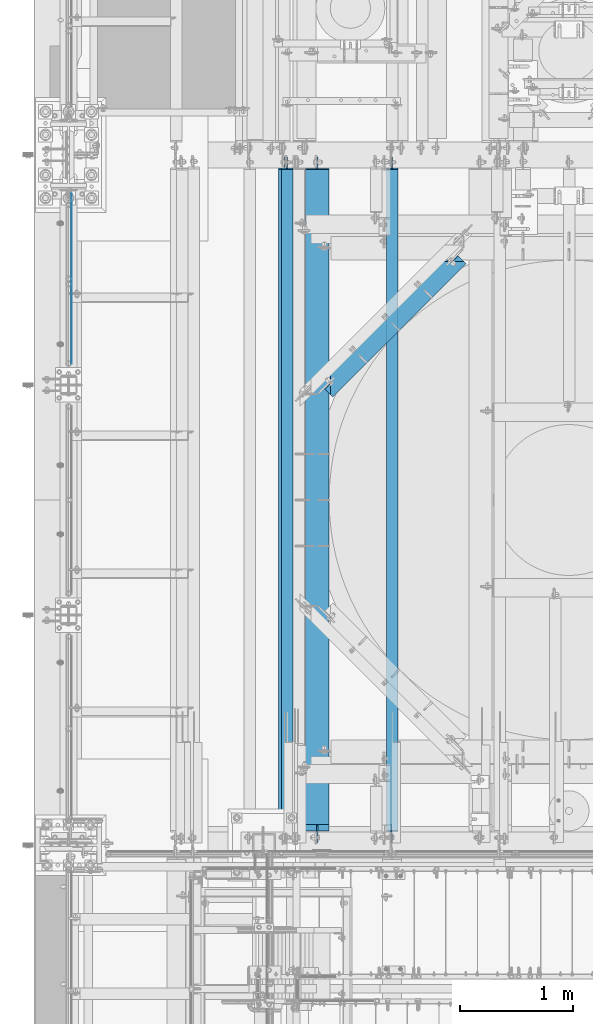
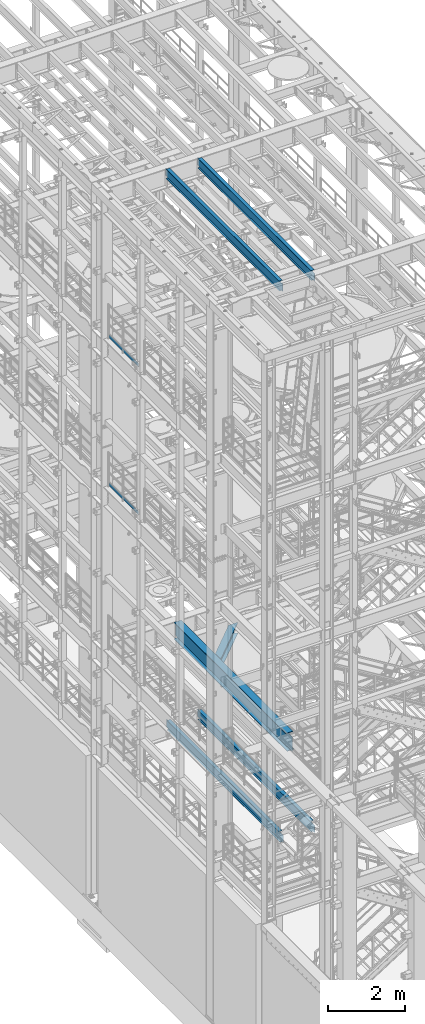
# One storey, part 1009 of 1876: 8 beams, 8 elements without a shape of their own.
"""IFC2X3 building model written with IfcOpenShell, lengths in millimetres."""

from ifc_helpers import new_model, si_unit, frame, origin_with_axes, place, context, subcontext, project, spatial, faceted_brep, material, type_object, element, aggregate, save


model = new_model("IFC2X3")

# Units and contexts
model_context = context("Model", 3, precision=1e-05, world=origin_with_axes())
body_context = subcontext(model_context, "Body", "Model", "MODEL_VIEW")
ifc_project = project(units=[si_unit("LENGTHUNIT", "METRE", prefix="MILLI"), si_unit("AREAUNIT", "SQUARE_METRE"), si_unit("VOLUMEUNIT", "CUBIC_METRE"), si_unit("MASSUNIT", "GRAM", prefix="KILO"), si_unit("TIMEUNIT", "SECOND"), si_unit("PLANEANGLEUNIT", "RADIAN"), si_unit("SOLIDANGLEUNIT", "STERADIAN"), si_unit("THERMODYNAMICTEMPERATUREUNIT", "DEGREE_CELSIUS"), si_unit("LUMINOUSINTENSITYUNIT", "LUMEN")], contexts=[model_context])

# Site, building, storey
site_placement = place(None, origin_with_axes())
site = spatial("IfcSite", under=ifc_project, at=site_placement, CompositionType="ELEMENT")
building_placement = place(site_placement, origin_with_axes())
building = spatial("IfcBuilding", under=site, at=building_placement, Name="Undefined", CompositionType="ELEMENT")
storey_placement = place(building_placement, origin_with_axes())
storey = spatial("IfcBuildingStorey", under=building, at=storey_placement, Name="Undefined", CompositionType="ELEMENT", Elevation=0.0)

# Assembly, beam
assembly_1_placement = place(storey_placement, origin_with_axes())
assembly_1 = element("IfcElementAssembly", 1, at=assembly_1_placement, inside=storey, Name="RAIL", AssemblyPlace="NOTDEFINED", PredefinedType="RIGID_FRAME")
ifc_material_1 = material(Name="STEEL/A36")
beam_type_1 = type_object("IfcBeamType", PredefinedType="NOTDEFINED")
beam_1_placement = place(assembly_1_placement, frame((27.3049999999948, -318.77, 18049.8809122948), z_axis=(0.0, 0.0, 1.0), x_axis=(0.0, 1.0, 0.0)))
beam_1 = element("IfcBeam", 2, at=beam_1_placement, type_object=beam_type_1, material=ifc_material_1, Name="PLATE", context=body_context, shape_type="Brep", body=[
    faceted_brep([(0.0, 3.17500000000018, -50.8000000000002), (0.0, 3.17500000000018, 50.8000000000002), (1497.965, 3.175, 50.7999999999993), (1497.965, 3.175, -50.7999999999993), (0.0, -3.17500000000018, 50.8000000000002), (1497.965, -3.175, 50.7999999999993), (0.0, -3.17500000000018, -50.8000000000002), (1497.965, -3.175, -50.7999999999993)], [[[0, 1, 2, 3]], [[1, 4, 5, 2]], [[4, 6, 7, 5]], [[6, 0, 3, 7]], [[5, 7, 3, 2]], [[6, 4, 1, 0]]]),
])
aggregate(assembly_1, [beam_1])

assembly_2_placement = place(storey_placement, origin_with_axes())
assembly_2 = element("IfcElementAssembly", 3, at=assembly_2_placement, inside=storey, Name="RAIL", AssemblyPlace="NOTDEFINED", PredefinedType="RIGID_FRAME")
beam_2_placement = place(assembly_2_placement, frame((27.3049999999948, -318.770000000002, 13376.2809122948), z_axis=(0.0, 0.0, 1.0), x_axis=(0.0, 1.0, 0.0)))
beam_2 = element("IfcBeam", 4, at=beam_2_placement, type_object=beam_type_1, material=ifc_material_1, Name="PLATE", context=body_context, shape_type="Brep", body=[
    faceted_brep([(0.0, 3.17500000000018, -50.8000000000002), (0.0, 3.17500000000018, 50.8000000000002), (1497.965, 3.175, 50.7999999999993), (1497.965, 3.175, -50.7999999999993), (0.0, -3.17500000000018, 50.8000000000002), (1497.965, -3.175, 50.7999999999993), (0.0, -3.17500000000018, -50.8000000000002), (1497.965, -3.175, -50.7999999999993)], [[[0, 1, 2, 3]], [[1, 4, 5, 2]], [[4, 6, 7, 5]], [[6, 0, 3, 7]], [[5, 7, 3, 2]], [[6, 4, 1, 0]]]),
])
aggregate(assembly_2, [beam_2])

assembly_3_placement = place(storey_placement, origin_with_axes())
assembly_3 = element("IfcElementAssembly", 5, at=assembly_3_placement, inside=storey, Name="BEAM", AssemblyPlace="NOTDEFINED", PredefinedType="RIGID_FRAME")
ifc_material_2 = material(Name="STEEL/A992")
beam_type_2 = type_object("IfcBeamType", Name="W12X16", PredefinedType="NOTDEFINED")
beam_3_placement = place(assembly_3_placement, frame((2857.5, -4572.0, 22402.8), z_axis=(0.0, 0.0, 1.0), x_axis=(0.0, 1.0, 0.0)))
beam_3 = element("IfcBeam", 6, at=beam_3_placement, type_object=beam_type_2, material=ifc_material_2, Name="BEAM", ObjectType="W12X16", context=body_context, shape_type="Brep", body=[
    faceted_brep([(19.84375, -3.17499999999995, -126.999999999996), (19.84375, 3.17499999999995, -126.999999999996), (102.393750190735, 3.17500000000018, -127.000000000001), (102.393750190735, -3.17500000000018, -127.000000000001), (107.25382970878, 3.17500000000018, -127.966729922588), (107.25382970878, -3.17500000000018, -127.966729922588), (111.374006176934, 3.17500000000018, -130.719743823067), (111.374006176934, -3.17500000000018, -130.719743823067), (114.127020077412, 3.17500000000018, -134.839920291221), (114.127020077412, -3.17500000000018, -134.839920291221), (115.09375, -3.17500000000018, -139.699999809266), (115.09375, 3.17500000000018, -139.699999809266), (115.09375, 3.17500000000018, -146.05), (115.09375, 50.8000000000002, -146.05), (115.09375, 50.8000000000002, -152.4), (115.09375, -50.8000000000002, -152.4), (115.09375, -50.8000000000002, -146.05), (115.09375, -3.17500000000018, -146.05), (127.79375, 3.17500000000018, 146.05), (127.79375, 50.8000000000002, 146.05), (5968.20625, 50.8, 146.05), (5968.20625, 3.17499999999995, 146.05), (115.093750190735, -3.17500000000018, 114.299999999999), (115.093750190735, 3.17500000000018, 114.299999999999), (19.84375, 3.17500000000018, 114.299999999999), (19.84375, -3.17500000000018, 114.299999999999), (119.95382970878, -3.17500000000018, 115.266729922587), (119.95382970878, 3.17500000000018, 115.266729922587), (124.074006176934, -3.17500000000018, 118.019743823065), (124.074006176934, 3.17500000000018, 118.019743823065), (126.827020077412, -3.17500000000018, 122.139920291219), (126.827020077412, 3.17500000000018, 122.139920291219), (127.79375, -3.17500000000018, 126.999999809264), (127.79375, 3.17500000000018, 126.999999809264), (127.79375, 50.8000000000002, 152.4), (127.79375, -50.8000000000002, 152.4), (5968.20625, -50.8, 152.4), (5968.20625, 50.8, 152.4), (127.79375, -50.8000000000002, 146.05), (5968.20625, -50.8, 146.05), (127.79375, -3.17500000000018, 146.05), (5968.20625, -3.17499999999995, 146.05), (5968.20625, -3.17499999999995, 126.999999809264), (5968.20625, 3.17499999999995, 126.999999809264), (5969.17297992259, -3.17499999999995, 122.139920291219), (5969.17297992259, 3.17499999999995, 122.139920291219), (5971.92599382307, -3.17499999999995, 118.019743823065), (5971.92599382307, 3.17499999999995, 118.019743823065), (5976.04617029122, -3.17499999999995, 115.266729922587), (5976.04617029122, 3.17499999999995, 115.266729922587), (5980.90624980927, -3.17499999999995, 114.299999999999), (5980.90624980927, 3.17499999999995, 114.299999999999), (6076.15625, -3.17499999999995, 114.299999999999), (6076.15625, 3.17499999999995, 114.299999999999), (6076.15625, -3.17499999999995, -126.999999999996), (6076.15625, 3.17499999999995, -126.999999999996), (5993.60624980927, -3.17499999999995, -127.000000000001), (5993.60624980927, 3.17499999999995, -127.000000000001), (5988.74617029122, -3.17499999999995, -127.966729922588), (5988.74617029122, 3.17499999999995, -127.966729922588), (5984.62599382307, -3.17499999999995, -130.719743823067), (5984.62599382307, 3.17499999999995, -130.719743823067), (5981.87297992259, -3.17499999999995, -134.839920291221), (5981.87297992259, 3.17499999999995, -134.839920291221), (5980.90625, -3.17499999999995, -139.699999809266), (5980.90625, 3.17499999999995, -139.699999809266), (5980.90625, -3.17499999999995, -146.05), (5980.90625, -50.8, -146.05), (5980.90625, -50.8, -152.4), (5980.90625, 50.8, -152.4), (5980.90625, 50.8, -146.05), (5980.90625, 3.17499999999995, -146.05)], [[[0, 1, 2, 3]], [[3, 2, 4, 5]], [[5, 4, 6, 7]], [[7, 6, 8, 9]], [[10, 11, 12, 13, 14, 15, 16, 17]], [[9, 8, 11, 10]], [[18, 19, 20, 21]], [[22, 23, 24, 25]], [[26, 27, 23, 22]], [[28, 29, 27, 26]], [[30, 31, 29, 28]], [[32, 33, 31, 30]], [[34, 35, 36, 37]], [[35, 38, 39, 36]], [[38, 40, 41, 39]], [[35, 34, 19, 18, 33, 32, 40, 38]], [[19, 34, 37, 20]], [[36, 39, 41, 42, 43, 21, 20, 37]], [[44, 45, 43, 42]], [[46, 47, 45, 44]], [[48, 49, 47, 46]], [[50, 51, 49, 48]], [[52, 53, 51, 50]], [[53, 52, 54, 55]], [[54, 56, 57, 55]], [[58, 59, 57, 56]], [[60, 61, 59, 58]], [[62, 63, 61, 60]], [[64, 65, 63, 62]], [[66, 67, 68, 69, 70, 71, 65, 64]], [[17, 16, 67, 66]], [[16, 15, 68, 67]], [[15, 14, 69, 68]], [[14, 13, 70, 69]], [[13, 12, 71, 70]], [[59, 61, 63, 65, 71, 12, 11, 8, 6, 4, 2, 1, 24, 23, 27, 29, 31, 33, 18, 21, 43, 45, 47, 49, 51, 53, 55, 57]], [[25, 24, 1, 0]], [[52, 50, 48, 46, 44, 42, 41, 40, 32, 30, 28, 26, 22, 25, 0, 3, 5, 7, 9, 10, 17, 66, 64, 62, 60, 58, 56, 54]]]),
])
aggregate(assembly_3, [beam_3])

assembly_4_placement = place(storey_placement, origin_with_axes())
assembly_4 = element("IfcElementAssembly", 7, at=assembly_4_placement, inside=storey, Name="BEAM", AssemblyPlace="NOTDEFINED", PredefinedType="RIGID_FRAME")
beam_4_placement = place(assembly_4_placement, frame((1905.0, -4572.0, 22402.8), z_axis=(0.0, 0.0, 1.0), x_axis=(0.0, 1.0, 0.0)))
beam_4 = element("IfcBeam", 8, at=beam_4_placement, type_object=beam_type_2, material=ifc_material_2, Name="BEAM", ObjectType="W12X16", context=body_context, shape_type="Brep", body=[
    faceted_brep([(19.84375, -3.17499999999995, -126.999999999996), (19.84375, 3.17499999999995, -126.999999999996), (102.393750190735, 3.17500000000018, -127.000000000001), (102.393750190735, -3.17500000000018, -127.000000000001), (107.25382970878, 3.17500000000018, -127.966729922588), (107.25382970878, -3.17500000000018, -127.966729922588), (111.374006176934, 3.17500000000018, -130.719743823067), (111.374006176934, -3.17500000000018, -130.719743823067), (114.127020077412, 3.17500000000018, -134.839920291221), (114.127020077412, -3.17500000000018, -134.839920291221), (115.09375, -3.17500000000018, -139.699999809266), (115.09375, 3.17500000000018, -139.699999809266), (115.09375, 3.17500000000018, -146.05), (115.09375, 50.8000000000002, -146.05), (115.09375, 50.8000000000002, -152.4), (115.09375, -50.8000000000002, -152.4), (115.09375, -50.8000000000002, -146.05), (115.09375, -3.17500000000018, -146.05), (127.79375, 3.17500000000018, 146.05), (127.79375, 50.8000000000002, 146.05), (5968.20625, 50.8, 146.05), (5968.20625, 3.17499999999995, 146.05), (115.093750190735, -3.17500000000018, 114.299999999999), (115.093750190735, 3.17500000000018, 114.299999999999), (19.84375, 3.17500000000018, 114.299999999999), (19.84375, -3.17500000000018, 114.299999999999), (119.95382970878, -3.17500000000018, 115.266729922587), (119.95382970878, 3.17500000000018, 115.266729922587), (124.074006176934, -3.17500000000018, 118.019743823065), (124.074006176934, 3.17500000000018, 118.019743823065), (126.827020077412, -3.17500000000018, 122.139920291219), (126.827020077412, 3.17500000000018, 122.139920291219), (127.79375, -3.17500000000018, 126.999999809264), (127.79375, 3.17500000000018, 126.999999809264), (127.79375, 50.8000000000002, 152.4), (127.79375, -50.8000000000002, 152.4), (5968.20625, -50.8, 152.4), (5968.20625, 50.8, 152.4), (127.79375, -50.8000000000002, 146.05), (5968.20625, -50.8, 146.05), (127.79375, -3.17500000000018, 146.05), (5968.20625, -3.17499999999995, 146.05), (5968.20625, -3.17499999999995, 126.999999809264), (5968.20625, 3.17499999999995, 126.999999809264), (5969.17297992259, -3.17499999999995, 122.139920291219), (5969.17297992259, 3.17499999999995, 122.139920291219), (5971.92599382307, -3.17499999999995, 118.019743823065), (5971.92599382307, 3.17499999999995, 118.019743823065), (5976.04617029122, -3.17499999999995, 115.266729922587), (5976.04617029122, 3.17499999999995, 115.266729922587), (5980.90624980927, -3.17499999999995, 114.299999999999), (5980.90624980927, 3.17499999999995, 114.299999999999), (6076.15625, -3.17499999999995, 114.299999999999), (6076.15625, 3.17499999999995, 114.299999999999), (6076.15625, -3.17499999999995, -126.999999999996), (6076.15625, 3.17499999999995, -126.999999999996), (5993.60624980927, -3.17499999999995, -127.000000000001), (5993.60624980927, 3.17499999999995, -127.000000000001), (5988.74617029122, -3.17499999999995, -127.966729922588), (5988.74617029122, 3.17499999999995, -127.966729922588), (5984.62599382307, -3.17499999999995, -130.719743823067), (5984.62599382307, 3.17499999999995, -130.719743823067), (5981.87297992259, -3.17499999999995, -134.839920291221), (5981.87297992259, 3.17499999999995, -134.839920291221), (5980.90625, -3.17499999999995, -139.699999809266), (5980.90625, 3.17499999999995, -139.699999809266), (5980.90625, -3.17499999999995, -146.05), (5980.90625, -50.8, -146.05), (5980.90625, -50.8, -152.4), (5980.90625, 50.8, -152.4), (5980.90625, 50.8, -146.05), (5980.90625, 3.17499999999995, -146.05)], [[[0, 1, 2, 3]], [[3, 2, 4, 5]], [[5, 4, 6, 7]], [[7, 6, 8, 9]], [[10, 11, 12, 13, 14, 15, 16, 17]], [[9, 8, 11, 10]], [[18, 19, 20, 21]], [[22, 23, 24, 25]], [[26, 27, 23, 22]], [[28, 29, 27, 26]], [[30, 31, 29, 28]], [[32, 33, 31, 30]], [[34, 35, 36, 37]], [[35, 38, 39, 36]], [[38, 40, 41, 39]], [[35, 34, 19, 18, 33, 32, 40, 38]], [[19, 34, 37, 20]], [[36, 39, 41, 42, 43, 21, 20, 37]], [[44, 45, 43, 42]], [[46, 47, 45, 44]], [[48, 49, 47, 46]], [[50, 51, 49, 48]], [[52, 53, 51, 50]], [[53, 52, 54, 55]], [[54, 56, 57, 55]], [[58, 59, 57, 56]], [[60, 61, 59, 58]], [[62, 63, 61, 60]], [[64, 65, 63, 62]], [[66, 67, 68, 69, 70, 71, 65, 64]], [[17, 16, 67, 66]], [[16, 15, 68, 67]], [[15, 14, 69, 68]], [[14, 13, 70, 69]], [[13, 12, 71, 70]], [[59, 61, 63, 65, 71, 12, 11, 8, 6, 4, 2, 1, 24, 23, 27, 29, 31, 33, 18, 21, 43, 45, 47, 49, 51, 53, 55, 57]], [[25, 24, 1, 0]], [[52, 50, 48, 46, 44, 42, 41, 40, 32, 30, 28, 26, 22, 25, 0, 3, 5, 7, 9, 10, 17, 66, 64, 62, 60, 58, 56, 54]]]),
])
aggregate(assembly_4, [beam_4])

assembly_5_placement = place(storey_placement, origin_with_axes())
assembly_5 = element("IfcElementAssembly", 9, at=assembly_5_placement, inside=storey, Name="BEAM", AssemblyPlace="NOTDEFINED", PredefinedType="RIGID_FRAME")
beam_5_placement = place(assembly_5_placement, frame((2857.5, -4572.0, 4978.4), z_axis=(0.0, 0.0, 1.0), x_axis=(0.0, 1.0, 0.0)))
beam_5 = element("IfcBeam", 10, at=beam_5_placement, type_object=beam_type_2, material=ifc_material_2, Name="BEAM", ObjectType="W12X16", context=body_context, shape_type="Brep", body=[
    faceted_brep([(23.0187500000002, -3.17499999999995, -127.0), (23.0187500000002, 3.17499999999995, -127.0), (105.568750190733, 3.17500002409543, -127.0), (105.568750190733, -3.17499999999995, -127.0), (110.428829708779, 3.17500002425345, -127.966729922588), (110.428829708779, -3.17499999999995, -127.966729922588), (114.549006176932, 3.17500002470138, -130.719743823066), (114.549006176932, -3.17499999999995, -130.719743823066), (117.302020077411, 3.17500002537099, -134.83992029122), (117.302020077411, -3.17499999999995, -134.83992029122), (118.268749999998, -3.17499999999995, -139.699999809265), (118.268749999998, 3.17500002616043, -139.699999809265), (118.268749999998, 3.17500008940715, -146.05), (118.268749999998, 50.8000000000002, -146.05), (118.268749999998, 50.8000000000002, -152.4), (118.268749999998, -50.8, -152.4), (118.268749999998, -50.8, -146.05), (118.268749999998, -3.17499999999995, -146.05), (5968.20625, 50.8, 146.05), (5968.20625, 3.17499999999995, 146.05), (181.768749999998, 3.17499999999995, 146.05), (181.768749999998, 50.8, 146.05), (169.068750190733, -3.17499999999995, 101.6), (169.068750190733, 3.17499998798007, 101.6), (23.0187500000002, 3.17499999999995, 101.6), (23.0187500000002, -3.17499999999995, 101.6), (173.928829708779, -3.17499999999995, 102.566729922588), (173.928829708779, 3.17499998782432, 102.566729922588), (178.049006176932, -3.17499999999995, 105.319743823066), (178.049006176932, 3.17499998738072, 105.319743823066), (180.802020077411, -3.17499999999995, 109.43992029122), (180.802020077411, 3.17499998671678, 109.43992029122), (181.768749999998, -3.17499999999995, 114.299999809266), (181.768749999998, 3.17499998593348, 114.299999809266), (5968.20625, -50.8, 152.4), (5968.20625, 50.8, 152.4), (181.768749999998, 50.8, 152.4), (181.768749999998, -50.8, 152.4), (5968.20625, -50.8, 146.05), (181.768749999998, -50.8, 146.05), (5968.20625, -3.17499999999995, 146.05), (181.768749999998, -3.17499999999995, 146.05), (5968.20625, -3.17499999999995, 126.999999809264), (5968.20625, 3.17499999999995, 126.999999809264), (5969.17297992259, -3.17499999999995, 122.139920291219), (5969.17297992259, 3.17499999999995, 122.139920291219), (5971.92599382307, -3.17499999999995, 118.019743823065), (5971.92599382307, 3.17499999999995, 118.019743823065), (5976.04617029122, -3.17499999999995, 115.266729922587), (5976.04617029122, 3.17499999999995, 115.266729922587), (5980.90624980927, -3.17499999999995, 114.299999999999), (5980.90624980927, 3.17499999999995, 114.299999999999), (6076.15625, -3.17499999999995, 114.299999999999), (6076.15625, 3.17499999999995, 114.299999999999), (6076.15625, -3.17499999999995, -126.999999999996), (6076.15625, 3.17499999999995, -126.999999999996), (5993.60624980927, -3.17499999999995, -127.000000000001), (5993.60624980927, 3.17499999999995, -127.000000000001), (5988.74617029122, -3.17499999999995, -127.966729922588), (5988.74617029122, 3.17499999999995, -127.966729922588), (5984.62599382307, -3.17499999999995, -130.719743823067), (5984.62599382307, 3.17499999999995, -130.719743823067), (5981.87297992259, -3.17499999999995, -134.839920291221), (5981.87297992259, 3.17499999999995, -134.839920291221), (5980.90625, -3.17499999999995, -139.699999809266), (5980.90625, 3.17499999999995, -139.699999809266), (5980.90625, -3.17499999999995, -146.05), (5980.90625, -50.8, -146.05), (5980.90625, -50.8, -152.4), (5980.90625, 50.8, -152.4), (5980.90625, 50.8, -146.05), (5980.90625, 3.17499999999995, -146.05)], [[[0, 1, 2, 3]], [[3, 2, 4, 5]], [[5, 4, 6, 7]], [[7, 6, 8, 9]], [[10, 11, 12, 13, 14, 15, 16, 17]], [[9, 8, 11, 10]], [[18, 19, 20, 21]], [[22, 23, 24, 25]], [[26, 27, 23, 22]], [[28, 29, 27, 26]], [[30, 31, 29, 28]], [[32, 33, 31, 30]], [[34, 35, 36, 37]], [[38, 34, 37, 39]], [[40, 38, 39, 41]], [[37, 36, 21, 20, 33, 32, 41, 39]], [[35, 18, 21, 36]], [[34, 38, 40, 42, 43, 19, 18, 35]], [[44, 45, 43, 42]], [[46, 47, 45, 44]], [[48, 49, 47, 46]], [[50, 51, 49, 48]], [[52, 53, 51, 50]], [[53, 52, 54, 55]], [[54, 56, 57, 55]], [[58, 59, 57, 56]], [[60, 61, 59, 58]], [[62, 63, 61, 60]], [[64, 65, 63, 62]], [[66, 67, 68, 69, 70, 71, 65, 64]], [[67, 66, 17, 16]], [[68, 67, 16, 15]], [[69, 68, 15, 14]], [[70, 69, 14, 13]], [[71, 70, 13, 12]], [[6, 4, 2, 1, 24, 23, 27, 29, 31, 33, 20, 19, 43, 45, 47, 49, 51, 53, 55, 57, 59, 61, 63, 65, 71, 12, 11, 8]], [[25, 24, 1, 0]], [[66, 64, 62, 60, 58, 56, 54, 52, 50, 48, 46, 44, 42, 40, 41, 32, 30, 28, 26, 22, 25, 0, 3, 5, 7, 9, 10, 17]]]),
])
aggregate(assembly_5, [beam_5])

assembly_6_placement = place(storey_placement, origin_with_axes())
assembly_6 = element("IfcElementAssembly", 11, at=assembly_6_placement, inside=storey, Name="BEAM", AssemblyPlace="NOTDEFINED", PredefinedType="RIGID_FRAME")
beam_6_placement = place(assembly_6_placement, frame((1930.4, -4572.0, 4978.4), z_axis=(0.0, 0.0, 1.0), x_axis=(0.0, 1.0, 0.0)))
beam_6 = element("IfcBeam", 12, at=beam_6_placement, type_object=beam_type_2, material=ifc_material_2, Name="BEAM", ObjectType="W12X16", context=body_context, shape_type="Brep", body=[
    faceted_brep([(23.0187500000002, -3.17499999999995, -127.0), (23.0187500000002, 3.17499999999995, -127.0), (105.568750190733, 3.17500002409543, -127.0), (105.568750190733, -3.17499999999995, -127.0), (110.428829708779, 3.17500002425345, -127.966729922588), (110.428829708779, -3.17499999999995, -127.966729922588), (114.549006176932, 3.17500002470138, -130.719743823066), (114.549006176932, -3.17499999999995, -130.719743823066), (117.302020077411, 3.17500002537099, -134.83992029122), (117.302020077411, -3.17499999999995, -134.83992029122), (118.268749999998, -3.17499999999995, -139.699999809265), (118.268749999998, 3.17500002616043, -139.699999809265), (118.268749999998, 3.17500008940715, -146.05), (118.268749999998, 50.8000000000002, -146.05), (118.268749999998, 50.8000000000002, -152.4), (118.268749999998, -50.8, -152.4), (118.268749999998, -50.8, -146.05), (118.268749999998, -3.17499999999995, -146.05), (5968.20625, 50.8, 146.05), (5968.20625, 3.17499999999995, 146.05), (181.768749999998, 3.17499999999995, 146.05), (181.768749999998, 50.8, 146.05), (169.068750190733, -3.17499999999995, 101.6), (169.068750190733, 3.17499998798007, 101.6), (23.0187500000002, 3.17499999999995, 101.6), (23.0187500000002, -3.17499999999995, 101.6), (173.928829708779, -3.17499999999995, 102.566729922588), (173.928829708779, 3.17499998782432, 102.566729922588), (178.049006176932, -3.17499999999995, 105.319743823066), (178.049006176932, 3.17499998738072, 105.319743823066), (180.802020077411, -3.17499999999995, 109.43992029122), (180.802020077411, 3.17499998671678, 109.43992029122), (181.768749999998, -3.17499999999995, 114.299999809266), (181.768749999998, 3.17499998593348, 114.299999809266), (5968.20625, -50.8, 152.4), (5968.20625, 50.8, 152.4), (181.768749999998, 50.8, 152.4), (181.768749999998, -50.8, 152.4), (5968.20625, -50.8, 146.05), (181.768749999998, -50.8, 146.05), (5968.20625, -3.17499999999995, 146.05), (181.768749999998, -3.17499999999995, 146.05), (5968.20625, -3.17499999999995, 126.999999809264), (5968.20625, 3.17499999999995, 126.999999809264), (5969.17297992259, -3.17499999999995, 122.139920291219), (5969.17297992259, 3.17499999999995, 122.139920291219), (5971.92599382307, -3.17499999999995, 118.019743823065), (5971.92599382307, 3.17499999999995, 118.019743823065), (5976.04617029122, -3.17499999999995, 115.266729922587), (5976.04617029122, 3.17499999999995, 115.266729922587), (5980.90624980927, -3.17499999999995, 114.299999999999), (5980.90624980927, 3.17499999999995, 114.299999999999), (6076.15625, -3.17499999999995, 114.299999999999), (6076.15625, 3.17499999999995, 114.299999999999), (6076.15625, -3.17499999999995, -126.999999999996), (6076.15625, 3.17499999999995, -126.999999999996), (5993.60624980927, -3.17499999999995, -127.000000000001), (5993.60624980927, 3.17499999999995, -127.000000000001), (5988.74617029122, -3.17499999999995, -127.966729922588), (5988.74617029122, 3.17499999999995, -127.966729922588), (5984.62599382307, -3.17499999999995, -130.719743823067), (5984.62599382307, 3.17499999999995, -130.719743823067), (5981.87297992259, -3.17499999999995, -134.839920291221), (5981.87297992259, 3.17499999999995, -134.839920291221), (5980.90625, -3.17499999999995, -139.699999809266), (5980.90625, 3.17499999999995, -139.699999809266), (5980.90625, -3.17499999999995, -146.05), (5980.90625, -50.8, -146.05), (5980.90625, -50.8, -152.4), (5980.90625, 50.8, -152.4), (5980.90625, 50.8, -146.05), (5980.90625, 3.17499999999995, -146.05)], [[[0, 1, 2, 3]], [[3, 2, 4, 5]], [[5, 4, 6, 7]], [[7, 6, 8, 9]], [[10, 11, 12, 13, 14, 15, 16, 17]], [[9, 8, 11, 10]], [[18, 19, 20, 21]], [[22, 23, 24, 25]], [[26, 27, 23, 22]], [[28, 29, 27, 26]], [[30, 31, 29, 28]], [[32, 33, 31, 30]], [[34, 35, 36, 37]], [[38, 34, 37, 39]], [[40, 38, 39, 41]], [[37, 36, 21, 20, 33, 32, 41, 39]], [[35, 18, 21, 36]], [[34, 38, 40, 42, 43, 19, 18, 35]], [[44, 45, 43, 42]], [[46, 47, 45, 44]], [[48, 49, 47, 46]], [[50, 51, 49, 48]], [[52, 53, 51, 50]], [[53, 52, 54, 55]], [[54, 56, 57, 55]], [[58, 59, 57, 56]], [[60, 61, 59, 58]], [[62, 63, 61, 60]], [[64, 65, 63, 62]], [[66, 67, 68, 69, 70, 71, 65, 64]], [[67, 66, 17, 16]], [[68, 67, 16, 15]], [[69, 68, 15, 14]], [[70, 69, 14, 13]], [[71, 70, 13, 12]], [[6, 4, 2, 1, 24, 23, 27, 29, 31, 33, 20, 19, 43, 45, 47, 49, 51, 53, 55, 57, 59, 61, 63, 65, 71, 12, 11, 8]], [[25, 24, 1, 0]], [[66, 64, 62, 60, 58, 56, 54, 52, 50, 48, 46, 44, 42, 40, 41, 32, 30, 28, 26, 22, 25, 0, 3, 5, 7, 9, 10, 17]]]),
])
aggregate(assembly_6, [beam_6])

assembly_7_placement = place(storey_placement, origin_with_axes())
assembly_7 = element("IfcElementAssembly", 13, at=assembly_7_placement, inside=storey, Name="BEAM", AssemblyPlace="NOTDEFINED", PredefinedType="RIGID_FRAME")
beam_type_3 = type_object("IfcBeamType", Name="W14X48", PredefinedType="NOTDEFINED")
beam_7_placement = place(assembly_7_placement, frame((2197.1, -607.95026853341, 7978.775), z_axis=(0.0, 0.0, 1.0), x_axis=(0.707106781186548, 0.707106781186547, 0.0)))
beam_7 = element("IfcBeam", 14, at=beam_7_placement, type_object=beam_type_3, material=ifc_material_2, Name="BEAM", ObjectType="W14X48", context=body_context, shape_type="Brep", body=[
    faceted_brep([(1662.22315108526, 3.96874999991564, -158.75), (1662.22332740131, 101.599999999926, -158.75), (185.657751276485, 101.600000000023, -158.75), (185.657575165281, 3.96811089828952, -158.750000051556), (168.736289360735, 3.96875000000455, 150.71492029122), (160.798792301766, -3.96874999999727, 150.71492029122), (162.165954616159, -3.96874999999727, 155.574999809265), (170.103451675127, 3.96875000000455, 155.574999809265), (164.842940486565, 3.96875000000364, 146.594743823066), (156.905443427596, -3.96874999999727, 146.594743823066), (159.016132125415, 3.96875000000364, 143.841729922588), (151.078635066447, -3.96874999999818, 143.841729922588), (152.142943030121, 3.96875000000364, 142.875), (144.205445971152, -3.96874999999818, 142.875), (90.9649929080101, 3.96875000000273, 142.875), (90.9649929080092, -3.96875, 142.875), (1756.91569494146, -101.6000000001, 174.625), (1756.91569494146, -101.6000000001, 158.75), (1756.91569494146, -75.1697674117638, 158.75), (1756.91569494146, -75.1697674117638, 174.625), (90.9649929080101, -101.600000000018, 174.625), (90.9649929080101, -101.600000000018, 158.75), (1685.71465114809, -3.96875000008572, 158.75), (90.9649929080092, -75.1697380898131, 158.75), (162.165954616159, -3.96874999999727, 158.75), (90.9649929080092, -3.96875, -158.75), (1756.91569490769, -3.96874999991178, -158.75), (1756.91569490769, -3.96874999991178, 142.875), (1703.67516644789, -3.96875000008663, 142.875), (1696.80197480592, -3.96875000008595, 143.841729922588), (1690.9751642858, -3.96875000008572, 146.594743823066), (1687.08181396905, -3.96875000008595, 150.71492029122), (1685.71465114809, -3.96875000008549, 155.574999809265), (90.9649929080101, -101.600000000018, -158.75), (1756.91569494146, -101.6000000001, -158.75), (90.9649929080101, -101.600000000018, -174.625), (1756.91569494146, -101.6000000001, -174.625), (1662.22332740131, 101.599999999926, -174.625), (1662.22315108295, 3.96811100703258, -174.625), (1756.91569494144, 3.96793999694864, -174.625), (90.9649929080097, 3.96956232788489, -174.625), (185.657575167596, 3.96939151866172, -174.625), (185.657751276485, 101.600000000023, -174.625), (1756.91569490769, 3.96875000008913, -158.75), (1756.91569494144, 3.96874999991155, -149.23352515146), (1756.91569494144, 3.96874999991155, -92.8149934398325), (1756.91569494144, 3.96874999991155, 137.264997438386), (1756.91569490769, 3.96875000008913, 142.875), (1695.73766350686, 3.96874999991428, 142.875), (1688.86447186488, 3.96874999991473, 143.841729922588), (1683.03766134476, 3.96874999991519, 146.594743823066), (1679.14431102802, 3.96874999991542, 150.71492029122), (1677.77714820706, 3.96874999991519, 155.574999809265), (1677.77714820706, 3.96874999991519, 158.75), (1580.14586203232, 101.599999999931, 158.75), (1580.14586203232, 101.599999999931, 174.625), (170.103451675127, 3.96875000000455, 158.75), (267.734665500438, 101.600000000026, 158.75), (267.734665500438, 101.600000000026, 174.625), (90.9649929080092, -75.1697380898131, 174.625), (90.9649929080101, 3.96875000000273, -158.75), (90.9649929080101, 3.96875000000273, -149.232875872044), (90.9649929080101, 3.96875000000273, -92.8150069252915), (90.9649929080101, 3.96875000000273, 137.264997440064)], [[[0, 1, 2, 3]], [[4, 5, 6, 7]], [[8, 9, 5, 4]], [[10, 11, 9, 8]], [[12, 13, 11, 10]], [[14, 15, 13, 12]], [[16, 17, 18, 19]], [[20, 21, 17, 16]], [[22, 18, 17, 21, 23, 24]], [[5, 9, 11, 13, 15, 25, 26, 27, 28, 29, 30, 31, 32, 22, 24, 6]], [[25, 33, 34, 26]], [[33, 35, 36, 34]], [[37, 38, 39, 36, 35, 40, 41, 42]], [[2, 42, 41, 3]], [[1, 37, 42, 2]], [[0, 38, 37, 1]], [[43, 39, 38, 0]], [[44, 45, 46, 47, 27, 26, 34, 36, 39, 43]], [[27, 47, 48, 28]], [[28, 48, 49, 29]], [[29, 49, 50, 30]], [[30, 50, 51, 31]], [[31, 51, 52, 32]], [[19, 18, 22, 32, 52, 53, 54, 55]], [[54, 53, 56, 57]], [[55, 54, 57, 58]], [[20, 16, 19, 55, 58, 59]], [[21, 20, 59, 23]], [[58, 57, 56, 7, 6, 24, 23, 59]], [[53, 52, 51, 50, 49, 48, 47, 46, 45, 44, 43, 0, 3, 60, 61, 62, 63, 14, 12, 10, 8, 4, 7, 56]], [[35, 33, 25, 15, 14, 63, 62, 61, 60, 40]], [[3, 41, 40, 60]]]),
])
aggregate(assembly_7, [beam_7])

assembly_8_placement = place(storey_placement, origin_with_axes())
assembly_8 = element("IfcElementAssembly", 15, at=assembly_8_placement, inside=storey, Name="BEAM", AssemblyPlace="NOTDEFINED", PredefinedType="RIGID_FRAME")
beam_type_4 = type_object("IfcBeamType", Name="W21X68", PredefinedType="NOTDEFINED")
beam_8_placement = place(assembly_8_placement, frame((2197.1, -4572.0, 7885.1125), z_axis=(0.0, 0.0, 1.0), x_axis=(0.0, 1.0, 0.0)))
beam_8 = element("IfcBeam", 16, at=beam_8_placement, type_object=beam_type_4, material=ifc_material_2, Name="BEAM", ObjectType="W21X68", context=body_context, shape_type="Brep", body=[
    faceted_brep([(23.0187554075283, -5.55624999999964, -242.8875), (23.0187554075283, 5.55624999999964, -242.8875), (111.918755598262, 5.55624999999964, -242.8875), (111.918755598262, -5.55624999999964, -242.8875), (116.778835116307, 5.55624999999964, -243.854229922587), (116.778835116307, -5.55624999999964, -243.854229922587), (120.899011584461, 5.55624999999964, -246.607243823066), (120.899011584461, -5.55624999999964, -246.607243823066), (123.652025484939, 5.55624999999964, -250.825), (123.652025484939, -5.55624999999964, -250.825), (124.618755407527, -104.775, -255.587499809265), (124.618755407527, 104.775, -255.587499809265), (124.618755407527, 104.775, -268.2875), (124.618755407527, -104.775, -268.2875), (123.652025484939, -104.775, -250.825), (123.652025484939, 104.775, -250.825), (5968.20625540753, 104.775, 250.825), (5968.20625540753, 5.55624999999964, 250.825), (181.768755407526, 5.55624999999964, 250.825), (181.768755407526, 104.775, 250.825), (169.068755598261, -5.55624999999964, 217.4875), (169.068755598261, 5.55624999999964, 217.4875), (23.0187554075283, 5.55624999999964, 217.4875), (23.0187554075283, -5.55624999999964, 217.4875), (173.928835116307, -5.55624999999964, 218.454229922588), (173.928835116307, 5.55624999999964, 218.454229922588), (178.04901158446, -5.55624999999964, 221.207243823066), (178.04901158446, 5.55624999999964, 221.207243823066), (180.802025484939, -5.55624999999964, 225.32742029122), (180.802025484939, 5.55624999999964, 225.32742029122), (181.768755407526, -5.55624999999964, 230.187499809265), (181.768755407526, 5.55624999999964, 230.187499809265), (5968.20625540753, -104.775, 268.2875), (5968.20625540753, 104.775, 268.2875), (181.768755407526, 104.775, 268.2875), (181.768755407526, -104.775, 268.2875), (5968.20625540753, -104.775, 250.825), (181.768755407526, -104.775, 250.825), (5968.20625540753, -5.55624999999964, 250.825), (181.768755407526, -5.55624999999964, 250.825), (5968.20625540753, -5.55624999999964, 242.887499809264), (5968.20625540753, 5.55624999999964, 242.887499809264), (5969.17298533012, -5.55624999999964, 238.027420291219), (5969.17298533012, 5.55624999999964, 238.027420291219), (5971.92599923059, -5.55624999999964, 233.907243823065), (5971.92599923059, 5.55624999999964, 233.907243823065), (5976.04617569875, -5.55624999999964, 231.154229922587), (5976.04617569875, 5.55624999999964, 231.154229922587), (5980.90625521679, -5.55624999999964, 230.187499999999), (5980.90625521679, 5.55624999999964, 230.187499999999), (6076.15625540753, -5.55624999999964, 230.187499999999), (6076.15625540753, 5.55624999999964, 230.187499999999), (6076.15625540753, -5.55624999999964, -242.887500000001), (6076.15625540753, 5.55624999999964, -242.887500000001), (5987.25625521679, -5.55624999999964, -242.887500000001), (5987.25625521679, 5.55624999999964, -242.887500000001), (5982.39617569875, -5.55624999999964, -243.854229922588), (5982.39617569875, 5.55624999999964, -243.854229922588), (5978.27599923059, -5.55624999999964, -246.607243823067), (5978.27599923059, 5.55624999999964, -246.607243823067), (5975.52298533012, -5.55624999999964, -250.825), (5975.52298533012, 5.55624999999964, -250.825), (5975.52298533012, -104.775, -250.825), (5974.55625540753, -104.775, -255.587499809266), (5974.55625540753, 104.775, -255.587499809266), (5975.52298533012, 104.775, -250.825), (5974.55625540753, -104.775, -268.2875), (5974.55625540753, 104.775, -268.2875)], [[[0, 1, 2, 3]], [[3, 2, 4, 5]], [[5, 4, 6, 7]], [[7, 6, 8, 9]], [[10, 11, 12, 13]], [[14, 9, 8, 15, 11, 10]], [[16, 17, 18, 19]], [[20, 21, 22, 23]], [[24, 25, 21, 20]], [[26, 27, 25, 24]], [[28, 29, 27, 26]], [[30, 31, 29, 28]], [[32, 33, 34, 35]], [[36, 32, 35, 37]], [[38, 36, 37, 39]], [[35, 34, 19, 18, 31, 30, 39, 37]], [[33, 16, 19, 34]], [[32, 36, 38, 40, 41, 17, 16, 33]], [[42, 43, 41, 40]], [[44, 45, 43, 42]], [[46, 47, 45, 44]], [[48, 49, 47, 46]], [[50, 51, 49, 48]], [[51, 50, 52, 53]], [[52, 54, 55, 53]], [[56, 57, 55, 54]], [[58, 59, 57, 56]], [[60, 61, 59, 58]], [[62, 63, 64, 65, 61, 60]], [[66, 67, 64, 63]], [[67, 66, 13, 12]], [[65, 64, 67, 12, 11, 15]], [[61, 65, 15, 8]], [[4, 2, 1, 22, 21, 25, 27, 29, 31, 18, 17, 41, 43, 45, 47, 49, 51, 53, 55, 57, 59, 61, 8, 6]], [[23, 22, 1, 0]], [[60, 58, 56, 54, 52, 50, 48, 46, 44, 42, 40, 38, 39, 30, 28, 26, 24, 20, 23, 0, 3, 5, 7, 9]], [[62, 60, 9, 14]], [[66, 63, 62, 14, 10, 13]]]),
])
aggregate(assembly_8, [beam_8])

save(model, "model.ifc")
